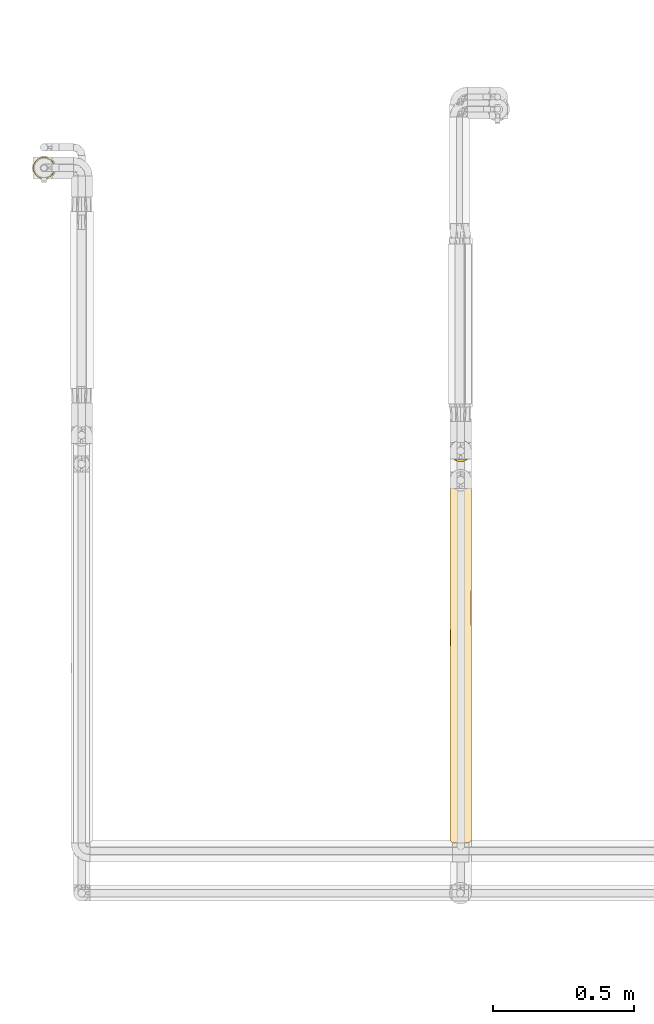
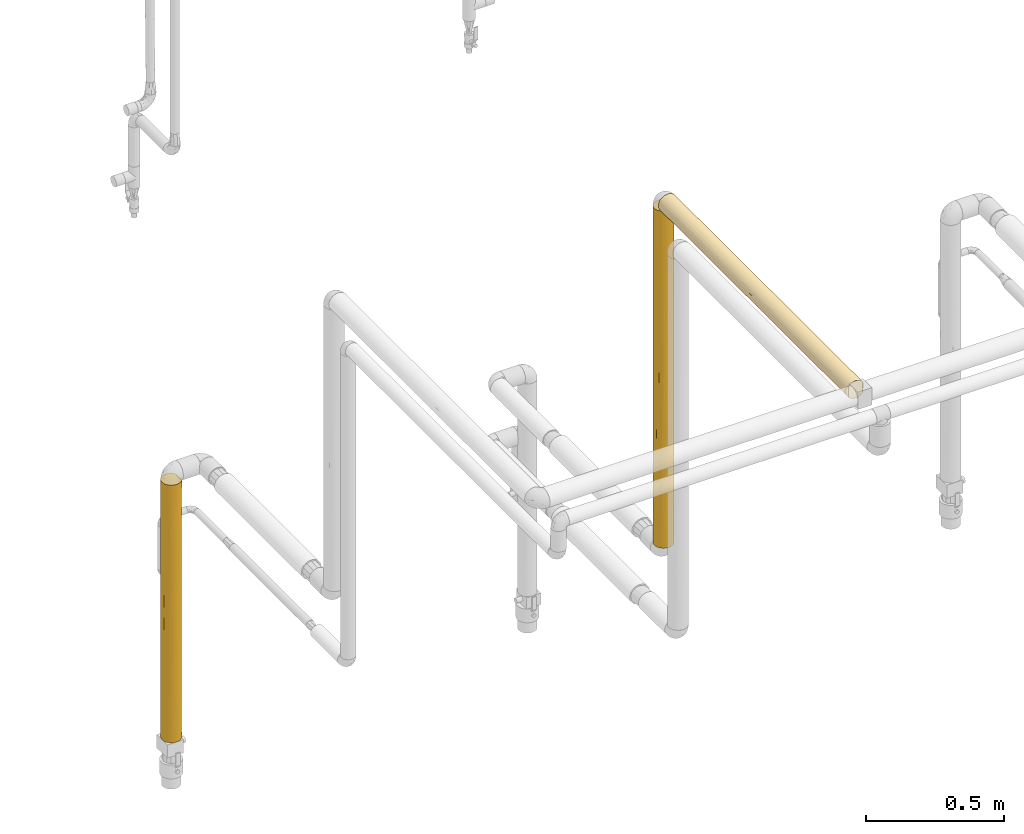
# One storey, part 25 of 827: 3 coverings.
"""IFC2X3 building model written with IfcOpenShell, lengths in millimetres."""

from ifc_helpers import new_model, entity, si_unit, converted_unit, derived_unit, direction, frame, origin, place, context, subcontext, project, spatial, faceted_brep, element, save


model = new_model("IFC2X3")

# Units and contexts
model_context = context("Model", 3, precision=0.01, world=origin(), true_north=direction((6.12303176911189e-17, 1.0)))
body_context = subcontext(model_context, "Body", "Model", "MODEL_VIEW")
ifc_project = project(units=[si_unit("LENGTHUNIT", "METRE", prefix="MILLI"), si_unit("AREAUNIT", "SQUARE_METRE"), si_unit("VOLUMEUNIT", "CUBIC_METRE"), converted_unit("PLANEANGLEUNIT", "DEGREE", entity("IfcRatioMeasure", 0.0174532925199433), si_unit("PLANEANGLEUNIT", "RADIAN"), dimensions=[0, 0, 0, 0, 0, 0, 0]), si_unit("MASSUNIT", "GRAM", prefix="KILO"), derived_unit("MASSDENSITYUNIT", [(si_unit("MASSUNIT", "GRAM", prefix="KILO"), 1), (si_unit("LENGTHUNIT", "METRE"), -3)]), derived_unit("MOMENTOFINERTIAUNIT", [(si_unit("LENGTHUNIT", "METRE"), 4)]), si_unit("TIMEUNIT", "SECOND"), si_unit("FREQUENCYUNIT", "HERTZ"), si_unit("THERMODYNAMICTEMPERATUREUNIT", "DEGREE_CELSIUS"), derived_unit("THERMALTRANSMITTANCEUNIT", [(si_unit("MASSUNIT", "GRAM", prefix="KILO"), 1), (si_unit("THERMODYNAMICTEMPERATUREUNIT", "KELVIN"), -1), (si_unit("TIMEUNIT", "SECOND"), -3)]), derived_unit("VOLUMETRICFLOWRATEUNIT", [(si_unit("LENGTHUNIT", "METRE"), 3), (si_unit("TIMEUNIT", "SECOND"), -1)]), derived_unit("MASSFLOWRATEUNIT", [(si_unit("MASSUNIT", "GRAM", prefix="KILO"), 1), (si_unit("TIMEUNIT", "SECOND"), -1)]), derived_unit("ROTATIONALFREQUENCYUNIT", [(si_unit("TIMEUNIT", "SECOND"), -1)]), si_unit("ELECTRICCURRENTUNIT", "AMPERE"), si_unit("ELECTRICVOLTAGEUNIT", "VOLT"), si_unit("POWERUNIT", "WATT"), si_unit("FORCEUNIT", "NEWTON", prefix="KILO"), si_unit("ILLUMINANCEUNIT", "LUX"), si_unit("LUMINOUSFLUXUNIT", "LUMEN"), si_unit("LUMINOUSINTENSITYUNIT", "CANDELA"), derived_unit("USERDEFINED", [(si_unit("MASSUNIT", "GRAM", prefix="KILO"), -1), (si_unit("LENGTHUNIT", "METRE"), -2), (si_unit("TIMEUNIT", "SECOND"), 3), (si_unit("LUMINOUSFLUXUNIT", "LUMEN"), 1)]), derived_unit("LINEARVELOCITYUNIT", [(si_unit("LENGTHUNIT", "METRE"), 1), (si_unit("TIMEUNIT", "SECOND"), -1)]), si_unit("PRESSUREUNIT", "PASCAL"), derived_unit("USERDEFINED", [(si_unit("LENGTHUNIT", "METRE"), -2), (si_unit("MASSUNIT", "GRAM", prefix="KILO"), 1), (si_unit("TIMEUNIT", "SECOND"), -2)]), derived_unit("LINEARFORCEUNIT", [(si_unit("MASSUNIT", "GRAM", prefix="KILO"), 1), (si_unit("LENGTHUNIT", "METRE"), 1), (si_unit("TIMEUNIT", "SECOND"), -2), (si_unit("LENGTHUNIT", "METRE"), -1)]), derived_unit("PLANARFORCEUNIT", [(si_unit("MASSUNIT", "GRAM", prefix="KILO"), 1), (si_unit("LENGTHUNIT", "METRE"), 1), (si_unit("TIMEUNIT", "SECOND"), -2), (si_unit("LENGTHUNIT", "METRE"), -2)])], contexts=[model_context])

# Site, building, storey
site_placement = place(None, origin())
site = spatial("IfcSite", under=ifc_project, at=site_placement, CompositionType="ELEMENT")
building_placement = place(site_placement, origin())
building = spatial("IfcBuilding", under=site, at=building_placement, CompositionType="ELEMENT")
storey_placement = place(building_placement, frame((0.0, 0.0, 28200.0)))
storey = spatial("IfcBuildingStorey", under=building, at=storey_placement, Name="08", CompositionType="ELEMENT", Elevation=28200.0)

# Coverings
covering_1_placement = place(storey_placement, frame((13238.8, 11124.54, 1327.5)))
element("IfcCovering", 1, at=covering_1_placement, inside=storey, Name=":ADSK_", ObjectType=":ADSK_", PredefinedType="INSULATION", context=body_context, shape_type="Brep", body=[
    faceted_brep([(77.51, 31.79, 1493.42), (78.4, 40.0, 1493.42), (77.09, 49.93, 1493.42), (73.25, 59.2, 1493.42), (67.15, 67.15, 1493.42), (59.2, 73.25, 1493.42), (49.93, 77.09, 1493.42), (40.0, 78.4, 1493.42), (30.06, 77.09, 1493.42), (20.8, 73.25, 1493.42), (12.84, 67.15, 1493.42), (6.74, 59.2, 1493.42), (2.9, 49.93, 1493.42), (1.6, 40.0, 1493.42), (2.48, 31.79, 1493.42), (5.09, 23.98, 1493.42), (9.31, 16.91, 1493.42), (14.94, 10.9, 1493.42), (65.05, 10.89, 1493.42), (70.68, 16.91, 1493.42), (74.9, 23.98, 1493.42), (77.09, 30.06, 1.6), (73.25, 20.8, 1.6), (67.15, 12.84, 1.6), (59.2, 6.74, 1.6), (49.93, 2.9, 1.6), (40.0, 1.6, 1.6), (30.06, 2.9, 1.6), (20.8, 6.74, 1.6), (12.84, 12.84, 1.6), (6.74, 20.8, 1.6), (2.9, 30.06, 1.6), (1.6, 40.0, 1.6), (2.48, 48.2, 1.6), (5.09, 56.01, 1.6), (9.31, 63.08, 1.6), (14.94, 69.1, 1.6), (65.05, 69.1, 1.6), (70.68, 63.08, 1.6), (74.9, 56.01, 1.6), (77.51, 48.2, 1.6), (78.4, 40.0, 1.6), (4.52, 25.3, 251.58), (31.75, 2.49, 1159.56), (29.53, 3.05, 806.95), (40.0, 1.6, 1051.38), (25.3, 4.52, 187.13), (16.62, 9.53, 286.82), (40.0, 1.6, 310.11), (31.96, 2.44, 304.82), (7.01, 20.33, 1276.37), (7.01, 20.33, 1009.83), (11.96, 13.75, 1207.78), (16.78, 9.41, 1088.18), (12.26, 13.43, 950.88), (3.58, 27.82, 1207.79), (3.63, 27.67, 531.14), (1.6, 40.0, 627.93), (1.6, 40.0, 434.34), (2.85, 30.25, 878.24), (1.6, 40.0, 217.97), (2.29, 32.74, 326.15), (8.22, 18.43, 724.24), (17.22, 9.08, 777.79), (40.0, 1.6, 1267.75), (40.0, 1.6, 1484.12), (33.21, 2.2, 1484.73), (9.53, 16.62, 196.07), (26.63, 4.0, 1486.52), (23.31, 5.41, 1110.0), (40.0, 1.6, 618.63), (32.14, 2.41, 544.6), (17.51, 8.87, 1300.97), (1.6, 40.0, 1277.05), (20.48, 6.93, 1489.45), (25.3, 4.52, 422.51), (16.84, 9.37, 532.43), (1.6, 40.0, 1060.68), (22.88, 5.62, 888.92), (23.19, 5.47, 651.06), (9.53, 16.62, 438.57), (1.6, 40.0, 867.09), (1.6, 40.0, 844.3), (1.6, 40.0, 650.72), (40.0, 1.6, 835.0), (63.37, 9.53, 286.82), (63.21, 9.4, 1088.15), (62.77, 9.08, 777.87), (67.73, 13.43, 950.88), (48.03, 2.44, 304.82), (47.86, 2.41, 544.6), (54.69, 4.52, 187.13), (62.48, 8.86, 1300.95), (59.51, 6.92, 1489.45), (56.67, 5.41, 1110.05), (54.69, 4.52, 422.51), (53.36, 3.99, 1486.52), (70.46, 16.62, 196.12), (48.23, 2.49, 1159.56), (46.78, 2.2, 1484.73), (68.03, 13.75, 1207.77), (76.41, 27.82, 1207.78), (78.4, 40.0, 1277.05), (50.46, 3.05, 806.96), (71.77, 18.43, 724.29), (72.98, 20.33, 1009.84), (77.14, 30.25, 878.16), (78.4, 40.0, 627.93), (78.4, 40.0, 650.71), (78.4, 40.0, 844.31), (78.4, 40.0, 867.09), (78.4, 40.0, 1060.68), (56.57, 5.36, 656.44), (75.47, 25.3, 251.58), (72.98, 20.33, 1276.35), (76.36, 27.67, 531.14), (62.87, 9.15, 532.02), (57.06, 5.6, 869.55), (78.4, 40.0, 434.34), (77.7, 32.74, 326.15), (78.4, 40.0, 217.97), (70.46, 16.62, 438.65), (76.41, 52.17, 287.23), (77.14, 49.74, 616.82), (62.48, 71.13, 194.06), (59.51, 73.07, 5.57), (72.98, 59.66, 218.66), (56.58, 74.63, 838.57), (62.77, 70.91, 717.19), (57.06, 74.39, 625.42), (54.69, 75.47, 1307.89), (48.03, 77.55, 1190.2), (68.03, 66.24, 287.24), (67.73, 66.56, 544.14), (72.98, 59.66, 485.18), (71.77, 61.56, 770.75), (76.36, 52.32, 963.88), (63.21, 70.58, 406.86), (40.0, 78.4, 227.27), (48.24, 77.5, 335.45), (46.78, 77.79, 10.29), (50.46, 76.94, 688.07), (56.68, 74.58, 384.99), (40.0, 78.4, 1184.91), (47.86, 77.58, 950.42), (70.46, 63.37, 1298.92), (53.36, 76.0, 8.5), (63.37, 70.46, 1208.19), (54.69, 75.47, 1072.51), (75.47, 54.69, 1243.43), (40.0, 78.4, 443.64), (62.87, 70.84, 963.02), (40.0, 78.4, 10.9), (40.0, 78.4, 876.39), (77.7, 47.25, 1168.86), (70.46, 63.37, 1056.41), (40.0, 78.4, 660.02), (31.75, 77.5, 335.45), (29.53, 76.94, 688.07), (16.78, 70.58, 406.86), (17.51, 71.13, 194.06), (11.96, 66.24, 287.24), (7.01, 59.66, 218.66), (16.62, 70.46, 1208.19), (20.48, 73.07, 5.57), (26.63, 76.0, 8.5), (33.21, 77.79, 10.29), (7.01, 59.66, 485.18), (3.58, 52.17, 287.23), (31.96, 77.55, 1190.2), (2.29, 47.25, 1168.86), (16.84, 70.63, 962.56), (25.3, 75.47, 1072.51), (23.31, 74.58, 384.99), (25.3, 75.47, 1307.89), (12.26, 66.56, 544.14), (8.22, 61.56, 770.75), (17.22, 70.91, 717.19), (2.85, 49.74, 616.82), (4.52, 54.69, 1243.43), (32.14, 77.58, 950.42), (3.63, 52.32, 963.88), (9.53, 63.37, 1298.92), (22.88, 74.37, 606.06), (23.19, 74.52, 843.93), (9.53, 63.37, 1056.41)], [[[0, 1, 2, 3, 4, 5, 6, 7, 8, 9, 10, 11, 12, 13, 14, 15, 16, 17, 18, 19, 20]], [[21, 22, 23, 24, 25, 26, 27, 28, 29, 30, 31, 32, 33, 34, 35, 36, 37, 38, 39, 40, 41]], [[31, 30, 42]], [[43, 44, 45]], [[46, 47, 28]], [[48, 49, 26]], [[50, 51, 52]], [[53, 52, 54]], [[55, 15, 14]], [[56, 57, 58]], [[55, 59, 51]], [[54, 52, 51]], [[60, 61, 58]], [[62, 63, 54]], [[52, 16, 50]], [[64, 65, 66]], [[55, 50, 15]], [[30, 29, 67]], [[43, 68, 69]], [[66, 68, 43]], [[70, 44, 71]], [[53, 72, 52]], [[14, 13, 73]], [[27, 46, 28]], [[28, 47, 29]], [[16, 52, 17]], [[72, 68, 74]], [[59, 57, 56]], [[75, 49, 71]], [[75, 76, 47]], [[45, 64, 43]], [[49, 75, 46]], [[72, 74, 17]], [[55, 73, 77]], [[59, 55, 77]], [[66, 43, 64]], [[43, 69, 44]], [[69, 78, 44]], [[78, 79, 44]], [[80, 56, 42]], [[32, 31, 60]], [[56, 80, 62]], [[75, 79, 76]], [[67, 47, 80]], [[59, 77, 81, 82, 83, 57]], [[48, 71, 49]], [[62, 59, 56]], [[42, 30, 67]], [[14, 73, 55]], [[61, 31, 42]], [[61, 56, 58]], [[31, 61, 60]], [[56, 61, 42]], [[47, 67, 29]], [[42, 67, 80]], [[62, 54, 51]], [[63, 78, 53]], [[62, 51, 59]], [[62, 80, 76]], [[63, 53, 54]], [[69, 68, 72]], [[52, 72, 17]], [[69, 72, 53]], [[27, 26, 49]], [[47, 46, 75]], [[27, 49, 46]], [[71, 48, 70]], [[84, 45, 44, 70]], [[79, 71, 44]], [[15, 50, 16]], [[51, 50, 55]], [[53, 78, 69]], [[79, 78, 63]], [[79, 63, 76]], [[79, 75, 71]], [[62, 76, 63]], [[80, 47, 76]], [[23, 85, 24]], [[86, 87, 88]], [[48, 89, 90]], [[91, 89, 25]], [[92, 18, 93]], [[92, 94, 86]], [[85, 95, 91]], [[96, 94, 92]], [[23, 22, 97]], [[64, 98, 99]], [[91, 25, 24]], [[18, 100, 19]], [[98, 64, 45]], [[101, 102, 0]], [[98, 103, 94]], [[88, 104, 105]], [[106, 107, 108, 109, 110, 111]], [[90, 112, 103]], [[21, 113, 22]], [[100, 114, 19]], [[100, 88, 105]], [[114, 20, 19]], [[20, 101, 0]], [[115, 106, 104]], [[111, 101, 106]], [[112, 116, 87]], [[96, 99, 98]], [[105, 101, 114]], [[112, 87, 117]], [[115, 118, 107]], [[106, 101, 105]], [[0, 102, 1]], [[99, 65, 64]], [[70, 90, 103]], [[98, 94, 96]], [[70, 48, 90]], [[117, 103, 112]], [[119, 115, 113]], [[21, 41, 120]], [[97, 113, 121]], [[97, 85, 23]], [[121, 104, 116]], [[104, 106, 105]], [[25, 89, 26]], [[107, 106, 115]], [[120, 119, 21]], [[111, 102, 101]], [[121, 113, 115]], [[119, 120, 118]], [[115, 119, 118]], [[21, 119, 113]], [[113, 97, 22]], [[85, 97, 121]], [[86, 88, 100]], [[87, 116, 104]], [[87, 104, 88]], [[115, 104, 121]], [[100, 18, 92]], [[86, 94, 117]], [[92, 93, 96]], [[100, 92, 86]], [[85, 91, 24]], [[89, 91, 95]], [[89, 95, 90]], [[89, 48, 26]], [[112, 90, 95]], [[103, 45, 84, 70]], [[105, 114, 100]], [[20, 114, 101]], [[45, 103, 98]], [[116, 95, 85]], [[95, 116, 112]], [[121, 116, 85]], [[86, 117, 87]], [[94, 103, 117]], [[118, 122, 123]], [[124, 37, 125]], [[126, 39, 38]], [[127, 128, 129]], [[130, 131, 6]], [[130, 6, 5]], [[122, 120, 40]], [[38, 132, 126]], [[132, 133, 134]], [[123, 135, 136]], [[123, 110, 109, 108, 107, 118]], [[136, 111, 110]], [[126, 134, 122]], [[137, 128, 133]], [[138, 139, 140]], [[139, 141, 142]], [[143, 131, 144]], [[37, 132, 38]], [[4, 3, 145]], [[124, 146, 142]], [[39, 122, 40]], [[137, 124, 142]], [[144, 127, 141]], [[147, 148, 130]], [[147, 5, 4]], [[146, 140, 139]], [[2, 149, 3]], [[138, 150, 139]], [[133, 135, 134]], [[127, 151, 128]], [[123, 122, 134]], [[40, 120, 41]], [[140, 152, 138]], [[153, 144, 141]], [[139, 142, 146]], [[153, 143, 144]], [[129, 141, 127]], [[154, 136, 149]], [[2, 1, 102]], [[145, 149, 155]], [[145, 147, 4]], [[155, 135, 151]], [[135, 123, 134]], [[6, 131, 7]], [[110, 123, 136]], [[102, 154, 2]], [[118, 120, 122]], [[155, 149, 136]], [[154, 102, 111]], [[136, 154, 111]], [[2, 154, 149]], [[149, 145, 3]], [[147, 145, 155]], [[137, 133, 132]], [[128, 151, 135]], [[128, 135, 133]], [[136, 135, 155]], [[132, 37, 124]], [[137, 142, 129]], [[124, 125, 146]], [[132, 124, 137]], [[147, 130, 5]], [[131, 130, 148]], [[131, 148, 144]], [[131, 143, 7]], [[127, 144, 148]], [[141, 150, 156, 153]], [[134, 126, 132]], [[39, 126, 122]], [[150, 141, 139]], [[151, 148, 147]], [[148, 151, 127]], [[155, 151, 147]], [[137, 129, 128]], [[142, 141, 129]], [[150, 157, 158]], [[159, 160, 161]], [[35, 162, 161]], [[9, 163, 10]], [[35, 161, 36]], [[164, 160, 165]], [[166, 165, 157]], [[150, 138, 157]], [[167, 161, 162]], [[168, 162, 34]], [[7, 143, 169]], [[73, 170, 77]], [[171, 163, 172]], [[157, 165, 173]], [[73, 13, 12]], [[169, 172, 174]], [[175, 161, 167]], [[176, 177, 175]], [[168, 178, 167]], [[12, 11, 179]], [[168, 34, 33]], [[8, 174, 9]], [[153, 158, 180]], [[159, 161, 175]], [[58, 168, 60]], [[178, 81, 181]], [[138, 152, 166]], [[9, 174, 163]], [[172, 169, 180]], [[11, 10, 182]], [[160, 164, 36]], [[168, 33, 60]], [[178, 168, 58]], [[166, 157, 138]], [[157, 173, 158]], [[173, 183, 158]], [[183, 184, 158]], [[179, 185, 181]], [[81, 77, 181]], [[181, 185, 176]], [[172, 184, 171]], [[182, 163, 185]], [[178, 58, 57, 83, 82, 81]], [[143, 180, 169]], [[176, 178, 181]], [[33, 32, 60]], [[179, 11, 182]], [[170, 12, 179]], [[170, 181, 77]], [[12, 170, 73]], [[181, 170, 179]], [[163, 182, 10]], [[179, 182, 185]], [[176, 175, 167]], [[177, 183, 159]], [[176, 167, 178]], [[176, 185, 171]], [[177, 159, 175]], [[173, 165, 160]], [[161, 160, 36]], [[173, 160, 159]], [[8, 7, 169]], [[163, 174, 172]], [[8, 169, 174]], [[180, 143, 153]], [[156, 150, 158, 153]], [[184, 180, 158]], [[34, 162, 35]], [[167, 162, 168]], [[159, 183, 173]], [[184, 183, 177]], [[184, 177, 171]], [[184, 172, 180]], [[176, 171, 177]], [[185, 163, 171]], [[74, 68, 66, 65, 99, 96, 93, 18, 17]], [[164, 165, 166, 152, 140, 146, 125, 37, 36]]]),
])
covering_2_placement = place(storey_placement, frame((13238.8, 9770.2, 2810.01)))
element("IfcCovering", 2, at=covering_2_placement, inside=storey, Name=":ADSK_", ObjectType=":ADSK_", PredefinedType="INSULATION", context=body_context, shape_type="Brep", body=[
    faceted_brep([(17.0, 1.6, 9.24), (24.05, 1.6, 5.06), (31.83, 1.6, 2.47), (40.0, 1.6, 1.6), (48.16, 1.6, 2.47), (55.94, 1.6, 5.06), (62.99, 1.6, 9.24), (69.0, 1.6, 14.83), (68.99, 1.6, 65.17), (62.99, 1.6, 70.75), (55.94, 1.6, 74.93), (48.16, 1.6, 77.52), (40.0, 1.6, 78.4), (31.83, 1.6, 77.52), (24.05, 1.6, 74.93), (17.0, 1.6, 70.75), (11.0, 1.6, 65.17), (10.99, 1.6, 14.83), (64.82, 1365.04, 10.73), (15.17, 1365.04, 10.73), (9.45, 1365.04, 16.75), (5.16, 1365.04, 23.87), (2.5, 1365.04, 31.75), (1.6, 1365.04, 40.02), (2.9, 1365.04, 49.96), (6.74, 1365.04, 59.22), (12.84, 1365.04, 67.18), (20.8, 1365.04, 73.28), (30.06, 1365.04, 77.11), (40.0, 1365.04, 78.42), (49.93, 1365.04, 77.11), (59.2, 1365.04, 73.28), (67.15, 1365.04, 67.18), (73.25, 1365.04, 59.22), (77.09, 1365.04, 49.96), (78.4, 1365.04, 40.02), (77.49, 1365.04, 31.75), (74.83, 1365.04, 23.87), (70.54, 1365.04, 16.76), (3.61, 1110.33, 27.73), (1.6, 1120.76, 40.02), (14.41, 374.53, 11.36), (8.99, 305.18, 17.35), (4.02, 8.57, 26.56), (2.99, 311.17, 29.74), (5.44, 351.14, 23.25), (26.77, 1358.28, 3.97), (33.28, 1356.52, 2.21), (31.19, 1105.65, 2.64), (7.11, 1181.97, 20.19), (2.21, 10.38, 33.17), (40.0, 1139.56, 1.62), (23.49, 999.3, 5.34), (20.67, 1361.15, 6.84), (6.98, 5.61, 20.38), (27.87, 192.62, 3.56), (5.49, 555.14, 23.16), (24.5, 660.01, 4.87), (30.7, 800.97, 2.75), (12.15, 1110.33, 13.58), (7.11, 963.08, 20.19), (40.0, 923.19, 1.61), (40.0, 706.81, 1.61), (40.0, 678.76, 1.61), (17.73, 1180.57, 8.73), (16.84, 976.18, 9.38), (27.87, 417.32, 3.57), (40.0, 490.44, 1.61), (40.0, 340.18, 1.6), (12.05, 847.36, 13.67), (10.93, 571.02, 14.92), (7.79, 739.89, 19.09), (3.4, 809.55, 28.37), (2.5, 567.03, 31.74), (1.6, 660.11, 40.01), (20.41, 259.99, 6.97), (1.6, 227.37, 40.0), (1.6, 876.49, 40.01), (40.0, 1355.93, 1.62), (19.81, 480.25, 7.34), (40.0, 246.02, 1.6), (17.45, 685.79, 8.92), (1.6, 1148.66, 40.02), (1.6, 443.74, 40.0), (1.6, 11.0, 40.0), (59.32, 1361.15, 6.84), (62.33, 1063.49, 8.78), (70.44, 386.41, 16.6), (66.14, 255.42, 11.88), (66.13, 516.92, 11.88), (72.88, 1104.06, 20.19), (68.39, 989.81, 14.16), (76.38, 1172.78, 27.73), (51.26, 558.44, 3.3), (48.0, 801.96, 2.46), (56.58, 814.05, 5.38), (50.09, 1057.68, 2.97), (56.42, 1161.63, 5.31), (53.22, 1358.28, 3.97), (46.71, 1356.52, 2.21), (59.58, 185.99, 6.97), (52.12, 255.41, 3.56), (78.4, 227.37, 40.0), (77.35, 264.93, 31.09), (78.4, 443.74, 40.0), (59.58, 405.09, 6.97), (73.01, 5.61, 20.38), (74.55, 368.15, 23.24), (75.97, 8.57, 26.56), (78.4, 1148.66, 40.02), (78.4, 1026.52, 40.02), (78.4, 876.49, 40.01), (78.4, 857.27, 40.01), (76.38, 946.16, 27.73), (77.22, 565.88, 30.59), (78.4, 688.02, 40.01), (78.4, 660.11, 40.01), (77.78, 10.38, 33.17), (72.46, 885.07, 19.5), (75.0, 703.96, 24.23), (70.84, 680.73, 17.14), (60.82, 622.1, 7.74), (64.73, 792.77, 10.64), (78.4, 11.0, 40.0), (63.37, 1080.89, 70.48), (70.46, 1112.2, 63.39), (70.53, 402.84, 63.29), (70.84, 686.54, 62.88), (66.31, 532.59, 67.97), (77.79, 1012.58, 46.81), (75.47, 986.95, 54.71), (71.05, 191.74, 62.59), (73.01, 5.61, 59.61), (74.54, 370.88, 56.76), (77.5, 335.56, 48.25), (76.73, 664.1, 51.21), (52.34, 1156.34, 76.38), (59.58, 475.23, 73.04), (66.14, 282.77, 68.12), (75.97, 8.57, 53.43), (40.0, 217.97, 78.4), (52.12, 282.76, 76.44), (77.78, 10.38, 46.82), (54.69, 947.51, 75.49), (62.46, 770.8, 71.15), (46.85, 1007.87, 77.8), (40.0, 1148.66, 78.42), (72.09, 902.46, 61.09), (49.79, 610.78, 77.14), (46.8, 799.53, 77.8), (40.0, 650.71, 78.41), (59.58, 216.9, 73.03), (40.0, 434.34, 78.4), (40.0, 867.09, 78.41), (67.67, 845.01, 66.63), (55.93, 728.85, 74.95), (27.87, 282.76, 76.44), (13.68, 532.59, 67.97), (13.85, 282.77, 68.12), (20.41, 475.23, 73.04), (9.46, 402.84, 63.29), (2.2, 1012.58, 46.81), (2.49, 335.56, 48.25), (3.26, 664.11, 51.21), (25.3, 947.51, 75.49), (27.65, 1156.34, 76.38), (16.62, 1080.89, 70.48), (33.14, 1007.87, 77.8), (5.45, 370.88, 56.76), (4.02, 8.57, 53.43), (6.98, 5.61, 59.61), (20.41, 216.9, 73.03), (8.94, 191.74, 62.59), (7.9, 902.46, 61.09), (9.15, 686.54, 62.88), (2.21, 10.38, 46.82), (17.53, 770.8, 71.15), (4.52, 986.95, 54.71), (9.53, 1112.2, 63.39), (33.19, 799.54, 77.8), (12.32, 845.01, 66.63), (30.2, 610.78, 77.14), (23.36, 672.11, 74.62)], [[[0, 1, 2, 3, 4, 5, 6, 7, 8, 9, 10, 11, 12, 13, 14, 15, 16, 17]], [[18, 19, 20, 21, 22, 23, 24, 25, 26, 27, 28, 29, 30, 31, 32, 33, 34, 35, 36, 37, 38]], [[39, 40, 22]], [[41, 17, 42]], [[43, 44, 45]], [[22, 21, 39]], [[46, 47, 48]], [[20, 49, 21]], [[50, 44, 43]], [[39, 21, 49]], [[47, 51, 48]], [[46, 52, 53]], [[54, 42, 17]], [[55, 2, 1]], [[56, 42, 45]], [[57, 52, 58]], [[59, 60, 49]], [[58, 61, 62, 63]], [[64, 52, 65]], [[58, 48, 61]], [[66, 63, 67, 68, 55]], [[69, 70, 71]], [[72, 73, 74]], [[59, 69, 60]], [[20, 19, 59]], [[75, 66, 55]], [[50, 76, 44]], [[0, 75, 1]], [[70, 41, 42]], [[60, 69, 71]], [[58, 52, 48]], [[60, 72, 39]], [[39, 77, 40]], [[43, 45, 54]], [[56, 73, 72]], [[2, 55, 68]], [[47, 78, 51]], [[63, 66, 58]], [[66, 79, 57]], [[0, 17, 41]], [[79, 75, 41]], [[64, 19, 53]], [[2, 68, 80, 3]], [[65, 81, 69]], [[60, 71, 72]], [[72, 77, 39]], [[56, 44, 73]], [[22, 40, 82, 23]], [[75, 55, 1]], [[65, 69, 59]], [[69, 81, 70]], [[81, 79, 41]], [[56, 70, 42]], [[59, 49, 20]], [[39, 49, 60]], [[48, 51, 61]], [[46, 48, 52]], [[44, 83, 73]], [[74, 77, 72]], [[81, 41, 70]], [[0, 41, 75]], [[57, 79, 81]], [[66, 75, 79]], [[52, 57, 81]], [[66, 57, 58]], [[59, 19, 64]], [[81, 65, 52]], [[52, 64, 53]], [[59, 64, 65]], [[70, 56, 71]], [[72, 71, 56]], [[73, 83, 74]], [[45, 42, 54]], [[44, 56, 45]], [[76, 50, 84]], [[76, 83, 44]], [[85, 18, 86]], [[87, 88, 89]], [[38, 90, 91]], [[37, 36, 92]], [[93, 94, 95]], [[95, 96, 97]], [[96, 98, 97]], [[51, 78, 99]], [[100, 88, 6]], [[93, 101, 67]], [[102, 103, 104]], [[51, 99, 96]], [[105, 100, 101]], [[106, 107, 108]], [[101, 93, 105]], [[94, 96, 95]], [[36, 35, 109, 110]], [[91, 18, 38]], [[88, 87, 7]], [[110, 111, 112, 113, 92]], [[114, 112, 115, 116, 104]], [[103, 102, 117]], [[98, 96, 99]], [[88, 7, 6]], [[97, 85, 86]], [[38, 37, 90]], [[104, 103, 114]], [[37, 92, 90]], [[118, 119, 120]], [[5, 4, 101]], [[89, 105, 121]], [[6, 5, 100]], [[89, 122, 120]], [[102, 123, 117]], [[119, 107, 120]], [[119, 113, 114]], [[103, 108, 107]], [[120, 91, 118]], [[120, 122, 91]], [[93, 95, 121]], [[89, 88, 105]], [[87, 106, 7]], [[4, 80, 101]], [[93, 62, 94]], [[110, 92, 36]], [[90, 92, 113]], [[89, 121, 122]], [[87, 120, 107]], [[95, 86, 122]], [[91, 122, 86]], [[101, 100, 5]], [[88, 100, 105]], [[108, 103, 117]], [[114, 103, 107]], [[112, 114, 113]], [[96, 94, 61]], [[120, 87, 89]], [[106, 87, 107]], [[91, 86, 18]], [[91, 90, 118]], [[90, 113, 118]], [[85, 97, 98]], [[113, 119, 118]], [[107, 119, 114]], [[93, 121, 105]], [[95, 122, 121]], [[93, 67, 63, 62]], [[62, 61, 94]], [[95, 97, 86]], [[96, 61, 51]], [[80, 4, 3]], [[101, 80, 68, 67]], [[32, 124, 125]], [[126, 127, 128]], [[129, 34, 130]], [[34, 109, 35]], [[131, 8, 132]], [[126, 131, 133]], [[33, 130, 34]], [[133, 134, 135]], [[136, 124, 31]], [[134, 102, 104]], [[33, 32, 125]], [[128, 137, 138]], [[139, 133, 132]], [[140, 11, 141]], [[102, 134, 142]], [[143, 144, 124]], [[145, 136, 146]], [[147, 135, 130]], [[148, 149, 150]], [[138, 151, 9]], [[8, 138, 9]], [[151, 10, 9]], [[10, 141, 11]], [[136, 30, 146]], [[152, 141, 148]], [[31, 124, 32]], [[139, 142, 134]], [[137, 141, 151]], [[135, 127, 133]], [[145, 146, 153]], [[148, 141, 137]], [[140, 12, 11]], [[142, 123, 102]], [[129, 135, 111]], [[134, 133, 139]], [[125, 124, 154]], [[135, 104, 116, 115, 112, 111]], [[143, 155, 144]], [[125, 147, 130]], [[155, 137, 144]], [[143, 145, 149]], [[128, 154, 144]], [[130, 33, 125]], [[30, 29, 146]], [[128, 144, 137]], [[129, 111, 110, 109]], [[127, 147, 154]], [[34, 129, 109]], [[135, 129, 130]], [[149, 145, 153]], [[145, 143, 136]], [[124, 136, 143]], [[31, 30, 136]], [[150, 152, 148]], [[149, 148, 155]], [[149, 153, 150]], [[126, 128, 138]], [[128, 127, 154]], [[138, 8, 131]], [[127, 126, 133]], [[133, 131, 132]], [[138, 131, 126]], [[137, 151, 138]], [[10, 151, 141]], [[141, 152, 140]], [[104, 135, 134]], [[135, 147, 127]], [[125, 154, 147]], [[124, 144, 154]], [[149, 155, 143]], [[137, 155, 148]], [[13, 140, 156]], [[157, 158, 159]], [[160, 158, 157]], [[24, 82, 161]], [[162, 163, 83]], [[164, 165, 166]], [[164, 167, 165]], [[165, 167, 146]], [[162, 168, 163]], [[169, 170, 168]], [[29, 28, 146]], [[159, 158, 171]], [[158, 15, 171]], [[172, 170, 16]], [[156, 171, 14]], [[27, 26, 166]], [[173, 163, 174]], [[175, 162, 76]], [[76, 84, 175]], [[176, 164, 166]], [[161, 82, 40, 77]], [[24, 177, 25]], [[160, 172, 158]], [[175, 169, 162]], [[16, 15, 158]], [[166, 26, 178]], [[153, 167, 179]], [[173, 174, 180]], [[181, 159, 156]], [[156, 14, 13]], [[163, 77, 74, 83]], [[181, 156, 152]], [[162, 169, 168]], [[83, 76, 162]], [[168, 174, 163]], [[161, 163, 177]], [[161, 77, 163]], [[26, 25, 178]], [[176, 159, 182]], [[181, 150, 179]], [[182, 164, 176]], [[25, 177, 178]], [[173, 178, 177]], [[24, 23, 82]], [[153, 146, 167]], [[180, 178, 173]], [[176, 180, 157]], [[24, 161, 177]], [[165, 146, 28]], [[164, 182, 179]], [[28, 27, 165]], [[166, 165, 27]], [[164, 179, 167]], [[176, 157, 159]], [[150, 181, 152]], [[150, 153, 179]], [[160, 174, 168]], [[174, 160, 157]], [[172, 168, 170]], [[158, 172, 16]], [[168, 172, 160]], [[14, 171, 15]], [[159, 171, 156]], [[140, 13, 12]], [[140, 152, 156]], [[163, 173, 177]], [[174, 157, 180]], [[176, 166, 180]], [[178, 180, 166]], [[159, 181, 182]], [[182, 181, 179]], [[7, 106, 108, 117, 123, 142, 139, 132, 8]], [[175, 84, 50, 43, 54, 17, 16, 170, 169]], [[85, 98, 99, 78, 47, 46, 53, 19, 18]]]),
])
covering_3_placement = place(storey_placement, frame((11758.21, 12130.04, 376.5)))
element("IfcCovering", 3, at=covering_3_placement, inside=storey, Name=":ADSK_", ObjectType=":ADSK_", PredefinedType="INSULATION", context=body_context, shape_type="Brep", body=[
    faceted_brep([(56.01, 5.11, 1140.15), (63.08, 9.33, 1140.15), (69.1, 14.96, 1140.15), (69.1, 65.07, 1140.15), (63.08, 70.7, 1140.15), (56.01, 74.92, 1140.15), (48.2, 77.53, 1140.15), (40.0, 78.41, 1140.15), (30.06, 77.11, 1140.15), (20.8, 73.27, 1140.15), (12.84, 67.17, 1140.15), (6.74, 59.21, 1140.15), (2.9, 49.95, 1140.15), (1.6, 40.01, 1140.15), (2.9, 30.08, 1140.15), (6.74, 20.81, 1140.15), (12.84, 12.86, 1140.15), (20.8, 6.76, 1140.15), (30.06, 2.92, 1140.15), (40.0, 1.61, 1140.15), (48.2, 2.5, 1140.15), (77.09, 30.06, 0.0), (73.25, 20.8, 0.0), (67.15, 12.84, 0.0), (59.2, 6.74, 0.0), (49.93, 2.9, 0.0), (40.0, 1.6, 0.0), (30.06, 2.9, 0.0), (20.8, 6.74, 0.0), (12.84, 12.84, 0.0), (6.74, 20.8, 0.0), (2.9, 30.06, 0.0), (1.6, 40.0, 0.0), (2.9, 49.93, 0.0), (6.74, 59.2, 0.0), (12.84, 67.15, 0.0), (20.8, 73.25, 0.0), (30.06, 77.09, 0.0), (40.0, 78.4, 0.0), (49.93, 77.09, 0.0), (59.2, 73.25, 0.0), (67.15, 67.15, 0.0), (73.25, 59.2, 0.0), (77.09, 49.93, 0.0), (78.4, 40.0, 0.0), (4.52, 25.3, 273.04), (9.53, 16.62, 251.79), (3.49, 28.09, 570.07), (2.26, 32.87, 815.59), (1.6, 40.01, 707.4), (1.6, 40.0, 216.37), (2.26, 32.86, 324.56), (1.6, 40.0, 432.75), (16.62, 9.54, 340.25), (32.92, 2.26, 572.9), (25.3, 4.53, 667.8), (26.94, 3.89, 465.21), (25.3, 4.52, 262.62), (9.53, 16.63, 570.07), (1.6, 40.01, 923.77), (9.53, 16.63, 888.36), (4.52, 25.32, 867.11), (32.81, 2.28, 324.56), (16.62, 9.54, 837.34), (24.22, 5.0, 915.83), (31.72, 2.51, 812.15), (15.56, 10.38, 588.8), (40.0, 1.6, 432.75), (40.0, 1.6, 216.37), (1.6, 40.01, 786.45), (40.0, 1.61, 707.4), (40.0, 1.61, 786.45), (40.0, 1.61, 923.77), (63.37, 9.54, 265.06), (54.69, 4.52, 350.56), (65.56, 11.36, 813.69), (70.97, 17.31, 567.02), (71.09, 17.48, 861.05), (65.43, 11.23, 576.18), (70.46, 16.62, 251.27), (75.47, 25.31, 327.05), (77.56, 32.02, 565.42), (75.05, 24.32, 643.69), (47.05, 2.26, 324.56), (59.66, 7.02, 694.31), (59.66, 7.03, 933.08), (52.17, 3.59, 869.67), (48.63, 2.59, 570.07), (78.4, 40.01, 914.47), (77.79, 33.23, 1131.45), (77.01, 29.8, 824.26), (76.0, 26.65, 1133.25), (78.4, 40.01, 698.1), (73.07, 20.5, 1136.18), (74.6, 23.37, 840.24), (78.4, 40.01, 1130.85), (78.4, 40.0, 432.75), (77.75, 32.97, 324.56), (78.4, 40.0, 216.38), (77.56, 47.99, 565.42), (77.01, 50.22, 824.26), (75.47, 54.7, 327.06), (59.66, 72.99, 694.31), (54.69, 75.48, 350.56), (50.08, 77.06, 561.93), (65.56, 68.66, 813.7), (65.43, 68.78, 576.18), (76.0, 53.38, 1133.25), (77.79, 46.8, 1131.45), (40.0, 78.4, 216.37), (47.05, 77.75, 324.56), (63.37, 70.46, 265.06), (74.6, 56.65, 840.24), (70.46, 63.38, 251.27), (71.09, 62.54, 861.05), (73.07, 59.53, 1136.18), (40.0, 78.4, 432.75), (40.0, 78.41, 923.77), (50.28, 77.01, 815.59), (40.0, 78.41, 707.4), (70.97, 62.7, 567.02), (59.66, 72.99, 933.08), (75.05, 55.69, 643.68), (77.75, 47.03, 324.56), (2.5, 48.29, 812.15), (16.62, 70.48, 888.36), (25.3, 75.49, 867.11), (32.86, 77.73, 324.56), (32.86, 77.74, 815.59), (25.3, 75.48, 273.04), (2.27, 47.18, 324.56), (28.08, 76.51, 570.07), (2.25, 47.08, 572.9), (4.52, 54.7, 667.8), (3.88, 53.06, 465.21), (9.53, 63.38, 340.25), (10.37, 64.44, 588.79), (16.62, 70.47, 570.07), (4.98, 55.78, 915.83), (4.52, 54.69, 262.62), (16.62, 70.46, 251.79), (9.53, 63.39, 837.34)], [[[0, 1, 2, 3, 4, 5, 6, 7, 8, 9, 10, 11, 12, 13, 14, 15, 16, 17, 18, 19, 20]], [[21, 22, 23, 24, 25, 26, 27, 28, 29, 30, 31, 32, 33, 34, 35, 36, 37, 38, 39, 40, 41, 42, 43, 44]], [[45, 30, 46]], [[47, 48, 49]], [[50, 51, 52]], [[31, 45, 51]], [[29, 28, 53]], [[54, 55, 56]], [[57, 28, 27]], [[47, 45, 58]], [[47, 49, 52]], [[14, 13, 59]], [[50, 32, 31]], [[53, 28, 57]], [[46, 58, 45]], [[58, 60, 61]], [[54, 56, 62]], [[63, 17, 16]], [[60, 15, 61]], [[64, 55, 65]], [[60, 16, 15]], [[61, 15, 14]], [[63, 55, 64]], [[54, 65, 55]], [[31, 30, 45]], [[66, 55, 63]], [[67, 62, 68]], [[18, 65, 19]], [[58, 66, 60]], [[53, 66, 58]], [[48, 59, 69, 49]], [[58, 61, 47]], [[29, 46, 30]], [[47, 52, 51]], [[31, 51, 50]], [[47, 51, 45]], [[68, 62, 27]], [[53, 57, 56]], [[63, 16, 60]], [[29, 53, 46]], [[58, 46, 53]], [[27, 26, 68]], [[62, 67, 54]], [[27, 62, 57]], [[54, 67, 70, 71]], [[65, 54, 71]], [[65, 71, 72, 19]], [[64, 18, 17]], [[18, 64, 65]], [[63, 64, 17]], [[48, 47, 61]], [[59, 48, 14]], [[14, 48, 61]], [[56, 55, 66]], [[62, 56, 57]], [[66, 53, 56]], [[60, 66, 63]], [[73, 74, 24]], [[75, 76, 77]], [[78, 79, 76]], [[25, 68, 26]], [[74, 73, 78]], [[80, 81, 82]], [[74, 25, 24]], [[68, 83, 67]], [[84, 85, 86]], [[86, 0, 20]], [[87, 86, 70]], [[85, 1, 0]], [[87, 70, 67]], [[85, 75, 1]], [[23, 73, 24]], [[2, 1, 75]], [[88, 89, 90]], [[77, 76, 82]], [[89, 91, 90]], [[81, 92, 90]], [[2, 77, 93]], [[91, 93, 94]], [[95, 89, 88]], [[96, 97, 98]], [[73, 23, 79]], [[84, 86, 87]], [[80, 22, 21]], [[67, 83, 87]], [[94, 93, 77]], [[21, 98, 97]], [[81, 96, 92]], [[23, 22, 79]], [[78, 76, 75]], [[84, 87, 74]], [[20, 72, 86]], [[86, 85, 0]], [[75, 85, 84]], [[75, 84, 78]], [[75, 77, 2]], [[82, 81, 90]], [[81, 97, 96]], [[22, 80, 79]], [[76, 79, 80]], [[74, 78, 84]], [[79, 78, 73]], [[94, 82, 90]], [[80, 82, 76]], [[83, 25, 74]], [[25, 83, 68]], [[87, 83, 74]], [[21, 44, 98]], [[81, 80, 97]], [[21, 97, 80]], [[91, 94, 90]], [[77, 82, 94]], [[90, 92, 88]], [[72, 20, 19]], [[86, 72, 71, 70]], [[92, 99, 100]], [[96, 99, 92]], [[43, 42, 101]], [[102, 103, 104]], [[105, 106, 102]], [[100, 107, 108]], [[39, 109, 110]], [[103, 111, 40]], [[100, 112, 107]], [[42, 41, 113]], [[108, 88, 100]], [[114, 3, 115]], [[3, 114, 105]], [[116, 110, 109]], [[117, 118, 119]], [[104, 119, 118]], [[120, 106, 105]], [[5, 121, 118]], [[41, 40, 111]], [[117, 7, 6]], [[39, 103, 40]], [[122, 112, 100]], [[121, 5, 4]], [[113, 41, 111]], [[96, 98, 123]], [[115, 107, 112]], [[121, 105, 102]], [[5, 118, 6]], [[117, 6, 118]], [[103, 110, 104]], [[99, 122, 100]], [[43, 98, 44]], [[106, 103, 102]], [[113, 120, 101]], [[4, 3, 105]], [[118, 121, 102]], [[4, 105, 121]], [[120, 105, 114]], [[99, 96, 123]], [[122, 101, 120]], [[113, 111, 106]], [[101, 42, 113]], [[113, 106, 120]], [[103, 106, 111]], [[101, 122, 99]], [[114, 122, 120]], [[39, 38, 109]], [[116, 119, 104]], [[39, 110, 103]], [[104, 110, 116]], [[102, 104, 118]], [[123, 43, 101]], [[43, 123, 98]], [[99, 123, 101]], [[122, 114, 112]], [[112, 114, 115]], [[88, 108, 95]], [[88, 92, 100]], [[38, 37, 109]], [[8, 7, 117]], [[12, 124, 13]], [[125, 9, 126]], [[9, 8, 126]], [[127, 116, 109]], [[119, 128, 117]], [[37, 36, 129]], [[52, 130, 50]], [[131, 128, 119]], [[132, 133, 134]], [[135, 35, 34]], [[135, 136, 137]], [[132, 134, 130]], [[137, 136, 125]], [[119, 116, 131]], [[138, 133, 124]], [[125, 10, 9]], [[135, 34, 139]], [[140, 137, 129]], [[137, 125, 126]], [[141, 133, 138]], [[132, 124, 133]], [[141, 11, 10]], [[129, 137, 131]], [[139, 34, 33]], [[136, 133, 141]], [[36, 140, 129]], [[35, 140, 36]], [[131, 116, 127]], [[117, 128, 8]], [[137, 126, 131]], [[50, 130, 33]], [[135, 139, 134]], [[35, 135, 140]], [[137, 140, 135]], [[141, 10, 125]], [[131, 126, 128]], [[8, 128, 126]], [[33, 32, 50]], [[130, 52, 132]], [[33, 130, 139]], [[132, 52, 49, 69]], [[124, 132, 69]], [[124, 69, 59, 13]], [[138, 12, 11]], [[12, 138, 124]], [[141, 138, 11]], [[127, 37, 129]], [[37, 127, 109]], [[131, 127, 129]], [[134, 133, 136]], [[130, 134, 139]], [[136, 135, 134]], [[125, 136, 141]], [[2, 93, 91, 89, 95, 108, 107, 115, 3]]]),
])

save(model, "model.ifc")
